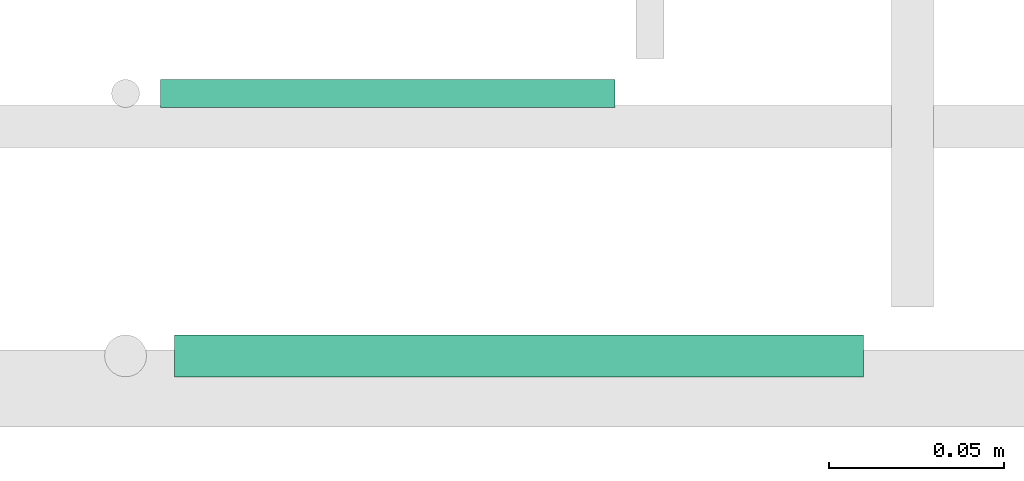
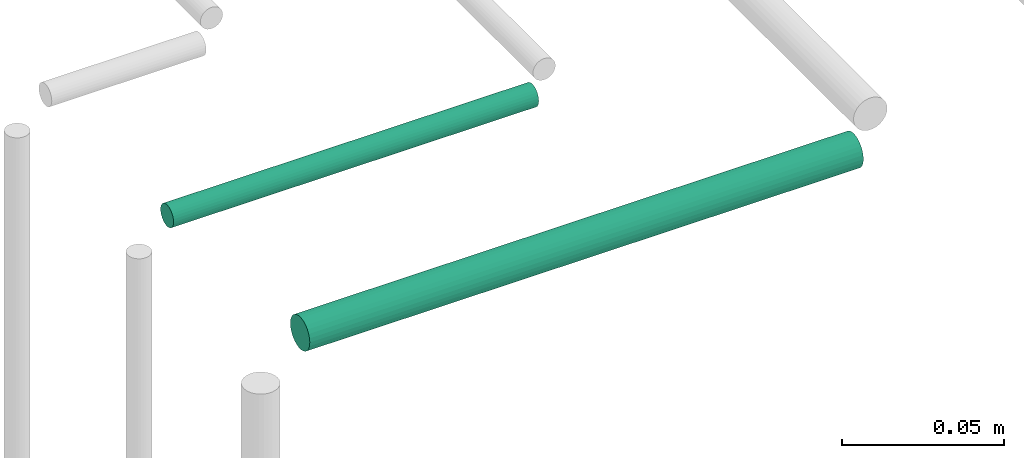
# One storey, part 160 of 331: 2 flow segments.
"""IFC2X3 building model written with IfcOpenShell, lengths in millimetres."""

from ifc_helpers import new_model, entity, si_unit, converted_unit, derived_unit, direction, frame, frame_2d, origin, place, context, subcontext, project, spatial, circle, extrude, type_object, element, save


model = new_model("IFC2X3")

# Units and contexts
model_context = context("Model", 3, precision=0.01, world=origin(), true_north=direction((6.12303176911189e-17, 1.0)))
body_context = subcontext(model_context, "Body", "Model", "MODEL_VIEW")
ifc_project = project(units=[si_unit("LENGTHUNIT", "METRE", prefix="MILLI"), si_unit("AREAUNIT", "SQUARE_METRE"), si_unit("VOLUMEUNIT", "CUBIC_METRE"), converted_unit("PLANEANGLEUNIT", "DEGREE", entity("IfcRatioMeasure", 0.0174532925199433), si_unit("PLANEANGLEUNIT", "RADIAN"), dimensions=[0, 0, 0, 0, 0, 0, 0]), si_unit("MASSUNIT", "GRAM", prefix="KILO"), derived_unit("MASSDENSITYUNIT", [(si_unit("MASSUNIT", "GRAM", prefix="KILO"), 1), (si_unit("LENGTHUNIT", "METRE"), -3)]), derived_unit("MOMENTOFINERTIAUNIT", [(si_unit("LENGTHUNIT", "METRE"), 4)]), si_unit("TIMEUNIT", "SECOND"), si_unit("FREQUENCYUNIT", "HERTZ"), si_unit("THERMODYNAMICTEMPERATUREUNIT", "DEGREE_CELSIUS"), derived_unit("THERMALTRANSMITTANCEUNIT", [(si_unit("MASSUNIT", "GRAM", prefix="KILO"), 1), (si_unit("THERMODYNAMICTEMPERATUREUNIT", "KELVIN"), -1), (si_unit("TIMEUNIT", "SECOND"), -3)]), derived_unit("VOLUMETRICFLOWRATEUNIT", [(si_unit("LENGTHUNIT", "METRE"), 3), (si_unit("TIMEUNIT", "SECOND"), -1)]), derived_unit("MASSFLOWRATEUNIT", [(si_unit("MASSUNIT", "GRAM", prefix="KILO"), 1), (si_unit("TIMEUNIT", "SECOND"), -1)]), derived_unit("ROTATIONALFREQUENCYUNIT", [(si_unit("TIMEUNIT", "SECOND"), -1)]), si_unit("ELECTRICCURRENTUNIT", "AMPERE"), si_unit("ELECTRICVOLTAGEUNIT", "VOLT"), si_unit("POWERUNIT", "WATT"), si_unit("FORCEUNIT", "NEWTON", prefix="KILO"), si_unit("ILLUMINANCEUNIT", "LUX"), si_unit("LUMINOUSFLUXUNIT", "LUMEN"), si_unit("LUMINOUSINTENSITYUNIT", "CANDELA"), derived_unit("USERDEFINED", [(si_unit("MASSUNIT", "GRAM", prefix="KILO"), -1), (si_unit("LENGTHUNIT", "METRE"), -2), (si_unit("TIMEUNIT", "SECOND"), 3), (si_unit("LUMINOUSFLUXUNIT", "LUMEN"), 1)]), derived_unit("LINEARVELOCITYUNIT", [(si_unit("LENGTHUNIT", "METRE"), 1), (si_unit("TIMEUNIT", "SECOND"), -1)]), si_unit("PRESSUREUNIT", "PASCAL"), derived_unit("USERDEFINED", [(si_unit("LENGTHUNIT", "METRE"), -2), (si_unit("MASSUNIT", "GRAM", prefix="KILO"), 1), (si_unit("TIMEUNIT", "SECOND"), -2)]), derived_unit("LINEARFORCEUNIT", [(si_unit("MASSUNIT", "GRAM", prefix="KILO"), 1), (si_unit("LENGTHUNIT", "METRE"), 1), (si_unit("TIMEUNIT", "SECOND"), -2), (si_unit("LENGTHUNIT", "METRE"), -1)]), derived_unit("PLANARFORCEUNIT", [(si_unit("MASSUNIT", "GRAM", prefix="KILO"), 1), (si_unit("LENGTHUNIT", "METRE"), 1), (si_unit("TIMEUNIT", "SECOND"), -2), (si_unit("LENGTHUNIT", "METRE"), -2)])], contexts=[model_context])

# Site, building, storey
site_placement = place(None, frame((0.0, -0.00077364408347762, 0.0)))
site = spatial("IfcSite", under=ifc_project, at=site_placement, CompositionType="ELEMENT")
building_placement = place(site_placement, origin())
building = spatial("IfcBuilding", under=site, at=building_placement, CompositionType="ELEMENT")
storey_placement = place(building_placement, origin())
storey = spatial("IfcBuildingStorey", under=building, at=storey_placement, CompositionType="ELEMENT", Elevation=0.0)

# Flow segments
pipe_segment_type = type_object("IfcPipeSegmentType", PredefinedType="NOTDEFINED")
flow_segment_1_placement = place(storey_placement, frame((40080.9367734621, 8604.40472776426, 7244.40472776409)))
element("IfcFlowSegment", 1, at=flow_segment_1_placement, inside=storey, type_object=pipe_segment_type, context=body_context, shape_type="SweptSolid", body=[
    extrude(circle(Radius=4.0, at=frame_2d((-6.49720277579036e-12, 0.0), x_axis=(1.0, 0.0))), frame((0.0, 5.59527223592149, 5.59527223591607), z_axis=(1.0, 0.0, 0.0), x_axis=(0.0, 1.0, 0.0)), (0.0, 0.0, 1.0), 129.893856447548),
])
flow_segment_2_placement = place(storey_placement, frame((40084.9367734621, 8527.40472776427, 7242.40472776409)))
element("IfcFlowSegment", 2, at=flow_segment_2_placement, inside=storey, type_object=pipe_segment_type, context=body_context, shape_type="SweptSolid", body=[
    extrude(circle(Radius=6.0, at=frame_2d((-3.24860138789518e-12, -1.08286712929839e-12), x_axis=(1.0, 0.0))), frame((0.0, 7.59527223591887, 7.5952722359167), z_axis=(1.0, 0.0, 0.0), x_axis=(0.0, 1.0, 0.0)), (0.0, 0.0, 1.0), 196.89385644755),
])

save(model, "model.ifc")
